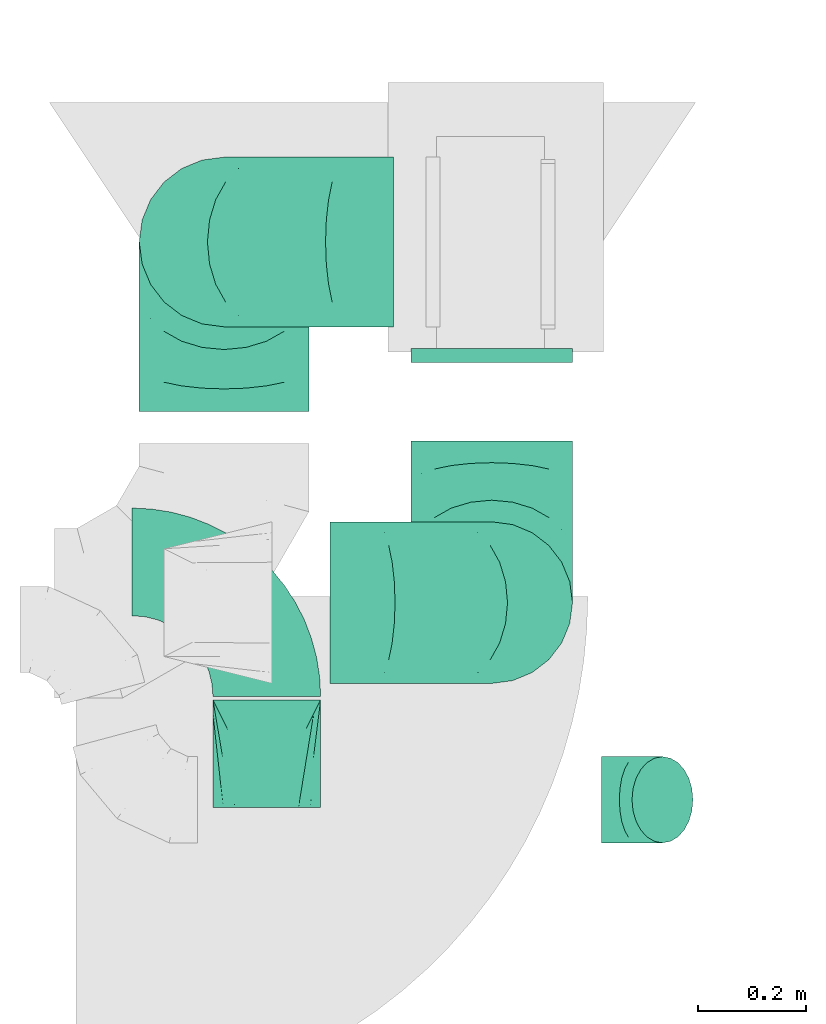
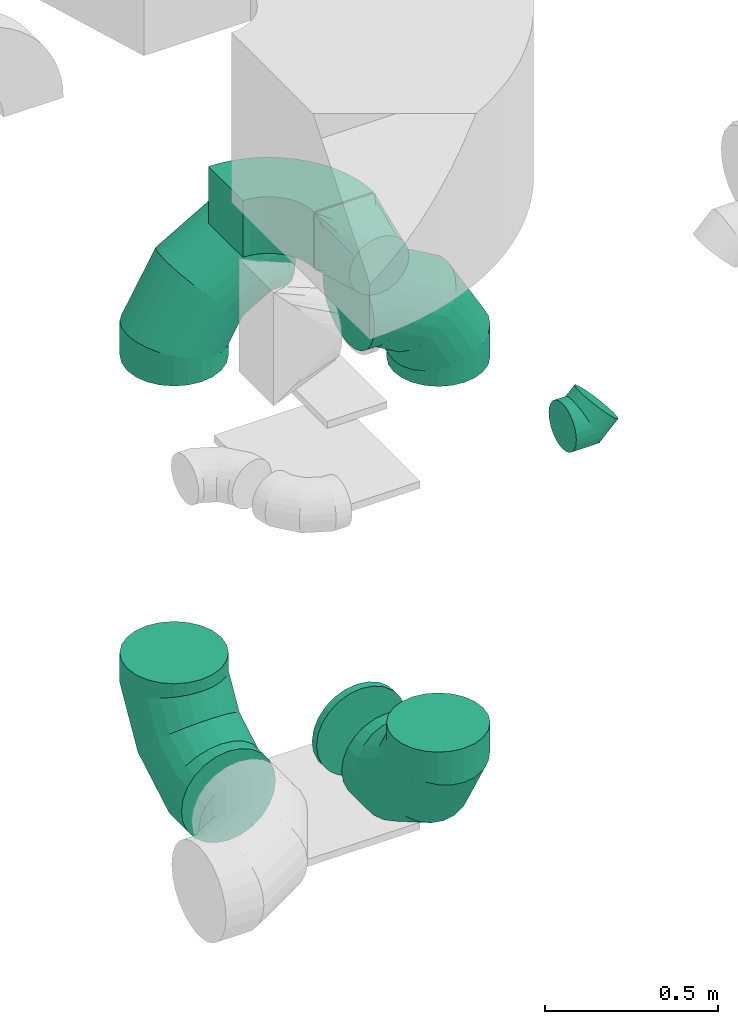
# One storey, part 32 of 59: 8 flow fittings.
"""IFC2X3 building model written with IfcOpenShell, lengths in millimetres."""

from ifc_helpers import new_model, entity, si_unit, converted_unit, derived_unit, direction, frame, frame_2d, origin, place, context, subcontext, project, spatial, polyline, circle_curve, parameter, trimmed, segment, composite_curve, outline, extrude, faceted_brep, source, transform, mapped, material, type_object, type_shapes, element, save


model = new_model("IFC2X3")

# Units and contexts
model_context = context("Model", 3, precision=0.01, world=origin(), true_north=direction((6.12303176911189e-17, 1.0)))
body_context = subcontext(model_context, "Body", "Model", "MODEL_VIEW")
ifc_project = project(units=[si_unit("LENGTHUNIT", "METRE", prefix="MILLI"), si_unit("AREAUNIT", "SQUARE_METRE"), si_unit("VOLUMEUNIT", "CUBIC_METRE"), converted_unit("PLANEANGLEUNIT", "DEGREE", entity("IfcRatioMeasure", 0.0174532925199433), si_unit("PLANEANGLEUNIT", "RADIAN"), dimensions=[0, 0, 0, 0, 0, 0, 0]), si_unit("MASSUNIT", "GRAM", prefix="KILO"), derived_unit("MASSDENSITYUNIT", [(si_unit("MASSUNIT", "GRAM", prefix="KILO"), 1), (si_unit("LENGTHUNIT", "METRE"), -3)]), derived_unit("MOMENTOFINERTIAUNIT", [(si_unit("LENGTHUNIT", "METRE"), 4)]), si_unit("TIMEUNIT", "SECOND"), si_unit("FREQUENCYUNIT", "HERTZ"), si_unit("THERMODYNAMICTEMPERATUREUNIT", "DEGREE_CELSIUS"), derived_unit("THERMALTRANSMITTANCEUNIT", [(si_unit("MASSUNIT", "GRAM", prefix="KILO"), 1), (si_unit("THERMODYNAMICTEMPERATUREUNIT", "KELVIN"), -1), (si_unit("TIMEUNIT", "SECOND"), -3)]), derived_unit("VOLUMETRICFLOWRATEUNIT", [(si_unit("LENGTHUNIT", "METRE"), 3), (si_unit("TIMEUNIT", "SECOND"), -1)]), derived_unit("MASSFLOWRATEUNIT", [(si_unit("MASSUNIT", "GRAM", prefix="KILO"), 1), (si_unit("TIMEUNIT", "SECOND"), -1)]), derived_unit("ROTATIONALFREQUENCYUNIT", [(si_unit("TIMEUNIT", "SECOND"), -1)]), si_unit("ELECTRICCURRENTUNIT", "AMPERE"), si_unit("ELECTRICVOLTAGEUNIT", "VOLT"), si_unit("POWERUNIT", "WATT"), si_unit("FORCEUNIT", "NEWTON", prefix="KILO"), si_unit("ILLUMINANCEUNIT", "LUX"), si_unit("LUMINOUSFLUXUNIT", "LUMEN"), si_unit("LUMINOUSINTENSITYUNIT", "CANDELA"), derived_unit("USERDEFINED", [(si_unit("MASSUNIT", "GRAM", prefix="KILO"), -1), (si_unit("LENGTHUNIT", "METRE"), -2), (si_unit("TIMEUNIT", "SECOND"), 3), (si_unit("LUMINOUSFLUXUNIT", "LUMEN"), 1)]), derived_unit("LINEARVELOCITYUNIT", [(si_unit("LENGTHUNIT", "METRE"), 1), (si_unit("TIMEUNIT", "SECOND"), -1)]), si_unit("PRESSUREUNIT", "PASCAL"), derived_unit("USERDEFINED", [(si_unit("LENGTHUNIT", "METRE"), -2), (si_unit("MASSUNIT", "GRAM", prefix="KILO"), 1), (si_unit("TIMEUNIT", "SECOND"), -2)]), derived_unit("LINEARFORCEUNIT", [(si_unit("MASSUNIT", "GRAM", prefix="KILO"), 1), (si_unit("LENGTHUNIT", "METRE"), 1), (si_unit("TIMEUNIT", "SECOND"), -2), (si_unit("LENGTHUNIT", "METRE"), -1)]), derived_unit("PLANARFORCEUNIT", [(si_unit("MASSUNIT", "GRAM", prefix="KILO"), 1), (si_unit("LENGTHUNIT", "METRE"), 1), (si_unit("TIMEUNIT", "SECOND"), -2), (si_unit("LENGTHUNIT", "METRE"), -2)])], contexts=[model_context])

# Site, building, storey
site_placement = place(None, origin())
site = spatial("IfcSite", under=ifc_project, at=site_placement, CompositionType="ELEMENT")
building_placement = place(site_placement, origin())
building = spatial("IfcBuilding", under=site, at=building_placement, CompositionType="ELEMENT")
storey_placement = place(building_placement, frame((0.0, 0.0, 28200.0)))
storey = spatial("IfcBuildingStorey", under=building, at=storey_placement, CompositionType="ELEMENT", Elevation=28200.0)

# Flow fittings
ifc_material = material()
duct_fitting_type_1 = type_object("IfcDuctFittingType", PredefinedType="NOTDEFINED", material=ifc_material)
shared_shape_1 = source(origin(), body_context, "Body", "Brep", [
    faceted_brep([(-66.27, 0.0, -80.0), (-66.27, -20.71, -77.27), (-66.27, -40.0, -69.28), (-66.27, -56.57, -56.57), (-66.27, -69.28, -40.0), (-66.27, -77.27, -20.71), (-66.27, -80.0, 0.0), (-66.27, -77.27, 20.71), (-66.27, -69.28, 40.0), (-66.27, -56.57, 56.57), (-66.27, -40.0, 69.28), (-66.27, -20.71, 77.27), (-66.27, 0.0, 80.0), (-66.27, 20.71, 77.27), (-66.27, 40.0, 69.28), (-66.27, 56.57, 56.57), (-66.27, 69.28, 40.0), (-66.27, 77.27, 20.71), (-66.27, 80.0, 0.0), (-66.27, 77.27, -20.71), (-66.27, 69.28, -40.0), (-66.27, 56.57, -56.57), (-66.27, 40.0, -69.28), (-66.27, 20.71, -77.27), (-8.58, 20.71, 77.27), (-16.57, 40.0, 69.28), (0.0, 0.0, 80.0), (-23.43, 56.57, 56.57), (-28.7, 69.28, 40.0), (-32.01, 77.27, 20.71), (-33.14, 80.0, 0.0), (-32.01, 77.27, -20.71), (-28.7, 69.28, -40.0), (-23.43, 56.57, -56.57), (-8.58, 20.71, -77.27), (0.0, 0.0, -80.0), (-16.57, 40.0, -69.28), (8.58, -20.71, -77.27), (16.57, -40.0, -69.28), (23.43, -56.57, -56.57), (28.7, -69.28, -40.0), (32.01, -77.27, -20.71), (33.14, -80.0, 0.0), (32.01, -77.27, 20.71), (28.7, -69.28, 40.0), (23.43, -56.57, 56.57), (16.57, -40.0, 69.28), (8.58, -20.71, 77.27), (46.86, 46.86, 80.0), (32.22, 61.5, 77.27), (18.58, 75.15, 69.28), (6.86, 86.86, 56.57), (-2.13, 95.85, 40.0), (-7.78, 101.5, 20.71), (-9.71, 103.43, 0.0), (-7.78, 101.5, -20.71), (-2.13, 95.85, -40.0), (6.86, 86.86, -56.57), (18.58, 75.15, -69.28), (32.22, 61.5, -77.27), (46.86, 46.86, -80.0), (61.5, 32.22, -77.27), (75.15, 18.58, -69.28), (86.86, 6.86, -56.57), (95.85, -2.13, -40.0), (101.5, -7.78, -20.71), (103.43, -9.71, 0.0), (101.5, -7.78, 20.71), (95.85, -2.13, 40.0), (86.86, 6.86, 56.57), (75.15, 18.58, 69.28), (61.5, 32.22, 77.27)], [[[0, 1, 2, 3, 4, 5, 6, 7, 8, 9, 10, 11, 12, 13, 14, 15, 16, 17, 18, 19, 20, 21, 22, 23]], [[24, 25, 14, 13]], [[26, 24, 13, 12]], [[14, 25, 27, 15]], [[28, 29, 17, 16]], [[28, 16, 15, 27]], [[30, 18, 17, 29]], [[31, 32, 20, 19]], [[30, 31, 19, 18]], [[32, 33, 21, 20]], [[34, 35, 0, 23]], [[36, 34, 23, 22]], [[33, 36, 22, 21]], [[1, 0, 35, 37]], [[2, 1, 37, 38]], [[38, 39, 3, 2]], [[5, 4, 40, 41]], [[6, 5, 41, 42]], [[39, 40, 4, 3]], [[6, 42, 43, 7]], [[7, 43, 44, 8]], [[8, 44, 45, 9]], [[9, 45, 46, 10]], [[10, 46, 47, 11]], [[26, 12, 11, 47]], [[24, 26, 48, 49]], [[25, 24, 49, 50]], [[27, 25, 50, 51]], [[29, 28, 52, 53]], [[30, 29, 53, 54]], [[51, 52, 28, 27]], [[30, 54, 55, 31]], [[31, 55, 56, 32]], [[57, 33, 32, 56]], [[36, 58, 59, 34]], [[34, 59, 60, 35]], [[58, 36, 33, 57]], [[35, 60, 61, 37]], [[37, 61, 62, 38]], [[63, 39, 38, 62]], [[40, 64, 65, 41]], [[41, 65, 66, 42]], [[64, 40, 39, 63]], [[43, 42, 66, 67]], [[44, 43, 67, 68]], [[68, 69, 45, 44]], [[47, 46, 70, 71]], [[26, 47, 71, 48]], [[69, 70, 46, 45]], [[59, 58, 57, 56, 55, 54, 53, 52, 51, 50, 49, 48, 71, 70, 69, 68, 67, 66, 65, 64, 63, 62, 61, 60]]]),
])
type_shapes(duct_fitting_type_1, [shared_shape_1])
flow_fitting_1_placement = place(storey_placement, frame((54162.65, 11858.0, 2105.0), z_axis=(0.0, 1.0, 0.0), x_axis=(-0.707106781186544, 0.0, -0.707106781186551)))
element("IfcFlowFitting", 1, at=flow_fitting_1_placement, inside=storey, type_object=duct_fitting_type_1, material=ifc_material, context=body_context, shape_type="MappedRepresentation", body=[
    mapped(shared_shape_1, transform((0.0, 0.0, 0.0), scale=1.0)),
])
duct_fitting_type_2 = type_object("IfcDuctFittingType", PredefinedType="NOTDEFINED", material=ifc_material)
shared_shape_2 = source(origin(), body_context, "Body", "Brep", [
    faceted_brep([(-315.0, 0.0, -157.5), (-315.0, -40.76, -152.13), (-315.0, -78.75, -136.4), (-315.0, -111.37, -111.37), (-315.0, -136.4, -78.75), (-315.0, -152.13, -40.76), (-315.0, -157.5, 0.0), (-315.0, -152.13, 40.76), (-315.0, -136.4, 78.75), (-315.0, -111.37, 111.37), (-315.0, -78.75, 136.4), (-315.0, -40.76, 152.13), (-315.0, 0.0, 157.5), (-315.0, 40.76, 152.13), (-315.0, 78.75, 136.4), (-315.0, 111.37, 111.37), (-315.0, 136.4, 78.75), (-315.0, 152.13, 40.76), (-315.0, 157.5, 0.0), (-315.0, 152.13, -40.76), (-315.0, 136.4, -78.75), (-315.0, 111.37, -111.37), (-315.0, 78.75, -136.4), (-315.0, 40.76, -152.13), (-241.52, 40.76, 152.13), (-251.7, 78.75, 136.4), (-230.6, 0.0, 157.5), (-260.44, 111.37, 111.37), (-271.36, 152.13, 40.76), (-272.8, 157.5, 0.0), (-267.14, 136.4, 78.75), (-267.14, 136.4, -78.75), (-260.44, 111.37, -111.37), (-271.36, 152.13, -40.76), (-241.52, 40.76, -152.13), (-230.6, 0.0, -157.5), (-251.7, 78.75, -136.4), (-219.67, -40.76, -152.13), (-209.5, -78.75, -136.4), (-200.75, -111.37, -111.37), (-194.05, -136.4, -78.75), (-189.83, -152.13, -40.76), (-188.39, -157.5, 0.0), (-189.83, -152.13, 40.76), (-194.05, -136.4, 78.75), (-200.75, -111.37, 111.37), (-209.5, -78.75, 136.4), (-219.67, -40.76, 152.13), (-114.25, 114.25, 152.13), (-142.05, 142.05, 136.4), (-84.4, 84.4, 157.5), (-165.93, 165.93, 111.37), (-184.25, 184.25, 78.75), (-195.77, 195.77, 40.76), (-199.7, 199.7, 0.0), (-195.77, 195.77, -40.76), (-184.25, 184.25, -78.75), (-165.93, 165.93, -111.37), (-114.25, 114.25, -152.13), (-84.4, 84.4, -157.5), (-142.05, 142.05, -136.4), (-54.56, 54.56, -152.13), (-26.75, 26.75, -136.4), (-2.88, 2.88, -111.37), (15.45, -15.45, -78.75), (26.97, -26.97, -40.76), (30.89, -30.89, 0.0), (26.97, -26.97, 40.76), (15.45, -15.45, 78.75), (-2.88, 2.88, 111.37), (-26.75, 26.75, 136.4), (-54.56, 54.56, 152.13), (-40.76, 241.52, 152.13), (-78.75, 251.7, 136.4), (0.0, 230.6, 157.5), (-111.37, 260.44, 111.37), (-136.4, 267.14, 78.75), (-152.13, 271.36, 40.76), (-157.5, 272.8, 0.0), (-152.13, 271.36, -40.76), (-136.4, 267.14, -78.75), (-111.37, 260.44, -111.37), (-40.76, 241.52, -152.13), (0.0, 230.6, -157.5), (-78.75, 251.7, -136.4), (40.76, 219.67, -152.13), (78.75, 209.5, -136.4), (111.37, 200.75, -111.37), (136.4, 194.05, -78.75), (152.13, 189.83, -40.76), (157.5, 188.39, 0.0), (152.13, 189.83, 40.76), (136.4, 194.05, 78.75), (111.37, 200.75, 111.37), (78.75, 209.5, 136.4), (40.76, 219.67, 152.13), (-40.76, 315.0, -152.13), (-78.75, 315.0, -136.4), (-111.37, 315.0, -111.37), (-136.4, 315.0, -78.75), (-152.13, 315.0, -40.76), (-157.5, 315.0, 0.0), (-152.13, 315.0, 40.76), (-136.4, 315.0, 78.75), (-111.37, 315.0, 111.37), (-78.75, 315.0, 136.4), (-40.76, 315.0, 152.13), (0.0, 315.0, 157.5), (40.76, 315.0, 152.13), (78.75, 315.0, 136.4), (111.37, 315.0, 111.37), (136.4, 315.0, 78.75), (152.13, 315.0, 40.76), (157.5, 315.0, 0.0), (152.13, 315.0, -40.76), (136.4, 315.0, -78.75), (111.37, 315.0, -111.37), (78.75, 315.0, -136.4), (40.76, 315.0, -152.13), (0.0, 315.0, -157.5)], [[[0, 1, 2, 3, 4, 5, 6, 7, 8, 9, 10, 11, 12, 13, 14, 15, 16, 17, 18, 19, 20, 21, 22, 23]], [[24, 25, 14, 13]], [[26, 24, 13, 12]], [[14, 25, 27, 15]], [[28, 29, 18, 17]], [[30, 28, 17, 16]], [[15, 27, 30, 16]], [[20, 31, 32, 21]], [[33, 31, 20, 19]], [[18, 29, 33, 19]], [[34, 35, 0, 23]], [[36, 34, 23, 22]], [[32, 36, 22, 21]], [[1, 0, 35, 37]], [[2, 1, 37, 38]], [[38, 39, 3, 2]], [[5, 4, 40, 41]], [[6, 5, 41, 42]], [[39, 40, 4, 3]], [[6, 42, 43, 7]], [[7, 43, 44, 8]], [[8, 44, 45, 9]], [[9, 45, 46, 10]], [[10, 46, 47, 11]], [[26, 12, 11, 47]], [[48, 49, 25, 24]], [[50, 48, 24, 26]], [[27, 25, 49, 51]], [[52, 53, 28, 30]], [[51, 52, 30, 27]], [[29, 28, 53, 54]], [[55, 56, 31, 33]], [[54, 55, 33, 29]], [[32, 31, 56, 57]], [[58, 59, 35, 34]], [[60, 58, 34, 36]], [[57, 60, 36, 32]], [[37, 35, 59, 61]], [[38, 37, 61, 62]], [[39, 38, 62, 63]], [[41, 40, 64, 65]], [[42, 41, 65, 66]], [[63, 64, 40, 39]], [[43, 42, 66, 67]], [[44, 43, 67, 68]], [[68, 69, 45, 44]], [[46, 45, 69, 70]], [[47, 46, 70, 71]], [[26, 47, 71, 50]], [[72, 73, 49, 48]], [[74, 72, 48, 50]], [[51, 49, 73, 75]], [[76, 77, 53, 52]], [[75, 76, 52, 51]], [[54, 53, 77, 78]], [[79, 80, 56, 55]], [[78, 79, 55, 54]], [[57, 56, 80, 81]], [[82, 83, 59, 58]], [[84, 82, 58, 60]], [[81, 84, 60, 57]], [[61, 59, 83, 85]], [[62, 61, 85, 86]], [[63, 62, 86, 87]], [[65, 64, 88, 89]], [[66, 65, 89, 90]], [[87, 88, 64, 63]], [[67, 66, 90, 91]], [[68, 67, 91, 92]], [[92, 93, 69, 68]], [[70, 69, 93, 94]], [[71, 70, 94, 95]], [[50, 71, 95, 74]], [[96, 97, 98, 99, 100, 101, 102, 103, 104, 105, 106, 107, 108, 109, 110, 111, 112, 113, 114, 115, 116, 117, 118, 119]], [[106, 105, 73, 72]], [[107, 106, 72, 74]], [[75, 73, 105, 104]], [[77, 76, 103, 102]], [[78, 77, 102, 101]], [[104, 103, 76, 75]], [[78, 101, 100, 79]], [[79, 100, 99, 80]], [[98, 81, 80, 99]], [[84, 97, 96, 82]], [[82, 96, 119, 83]], [[97, 84, 81, 98]], [[83, 119, 118, 85]], [[85, 118, 117, 86]], [[116, 87, 86, 117]], [[88, 115, 114, 89]], [[89, 114, 113, 90]], [[115, 88, 87, 116]], [[91, 90, 113, 112]], [[92, 91, 112, 111]], [[111, 110, 93, 92]], [[95, 94, 109, 108]], [[74, 95, 108, 107]], [[110, 109, 94, 93]]]),
])
type_shapes(duct_fitting_type_2, [shared_shape_2])
for number, where, z_axis, x_axis in (
    (2, (53395.67, 12893.51, 607.5), (1.0, 0.0, 0.0), (0.0, 1.0, 0.0)),
    (3, (53395.67, 12893.51, 2289.55), (0.0, 1.0, 0.0), (0.0, 0.0, 1.0)),
):
    element("IfcFlowFitting", number, at=place(storey_placement, frame(where, z_axis=z_axis, x_axis=x_axis)), inside=storey, type_object=duct_fitting_type_2, material=ifc_material, context=body_context, shape_type="MappedRepresentation", body=[
        mapped(shared_shape_2, transform((0.0, 0.0, 0.0), scale=1.0)),
    ])
duct_fitting_type_3 = type_object("IfcDuctFittingType", PredefinedType="NOTDEFINED", material=ifc_material)
shared_shape_3 = source(origin(), body_context, "Body", "Brep", [
    faceted_brep([(200.0, 30.9, 95.11), (200.0, 19.08, 96.98), (200.0, 9.54, 98.49), (200.0, 4.77, 99.24), (200.0, 0.0, 100.0), (200.0, -4.77, 99.24), (200.0, -9.54, 98.49), (200.0, -19.08, 96.98), (200.0, -30.9, 95.11), (200.0, -44.84, 88.0), (200.0, -58.78, 80.9), (200.0, -69.84, 69.84), (200.0, -80.9, 58.78), (200.0, -88.0, 44.84), (200.0, -95.11, 30.9), (200.0, -96.98, 19.08), (200.0, -98.49, 9.54), (200.0, -99.24, 4.77), (200.0, -100.0, 0.0), (200.0, -99.24, -4.77), (200.0, -98.49, -9.54), (200.0, -96.98, -19.08), (200.0, -95.11, -30.9), (200.0, -88.0, -44.84), (200.0, -80.9, -58.78), (200.0, -69.84, -69.84), (200.0, -58.78, -80.9), (200.0, -44.84, -88.0), (200.0, -30.9, -95.11), (200.0, -19.08, -96.98), (200.0, -9.54, -98.49), (200.0, -4.77, -99.24), (200.0, 0.0, -100.0), (200.0, 4.77, -99.24), (200.0, 9.54, -98.49), (200.0, 19.08, -96.98), (200.0, 30.9, -95.11), (200.0, 44.84, -88.0), (200.0, 58.78, -80.9), (200.0, 69.84, -69.84), (200.0, 80.9, -58.78), (200.0, 88.0, -44.84), (200.0, 95.11, -30.9), (200.0, 96.98, -19.08), (200.0, 98.49, -9.54), (200.0, 99.24, -4.77), (200.0, 100.0, 0.0), (200.0, 99.24, 4.77), (200.0, 98.49, 9.54), (200.0, 96.98, 19.08), (200.0, 95.11, 30.9), (200.0, 88.0, 44.84), (200.0, 80.9, 58.78), (200.0, 69.84, 69.84), (200.0, 58.78, 80.9), (200.0, 44.84, 88.0), (0.0, -100.0, 100.0), (0.0, 100.0, 100.0), (0.0, 100.0, -100.0), (0.0, -100.0, -100.0), (104.11, -47.94, 100.0), (100.0, -83.15, 87.43), (26.03, -86.99, 100.0), (78.09, -60.96, 100.0), (52.06, -73.97, 100.0), (188.01, -5.99, 100.0), (176.03, -11.99, 100.0), (152.06, -23.97, 100.0), (128.09, -35.96, 100.0), (52.06, -100.0, 73.97), (78.09, -100.0, 60.96), (104.11, -100.0, 47.94), (128.09, -100.0, 35.96), (152.06, -100.0, 23.97), (176.03, -100.0, 11.99), (188.01, -100.0, 5.99), (26.03, -100.0, 86.99), (26.03, -100.0, -86.99), (52.06, -100.0, -73.97), (78.09, -100.0, -60.96), (104.11, -100.0, -47.94), (128.09, -100.0, -35.96), (152.06, -100.0, -23.97), (176.03, -100.0, -11.99), (188.01, -100.0, -5.99), (100.0, -87.43, -83.15), (52.06, -73.97, -100.0), (78.09, -60.96, -100.0), (104.11, -47.94, -100.0), (128.09, -35.96, -100.0), (152.06, -23.97, -100.0), (176.03, -11.99, -100.0), (188.01, -5.99, -100.0), (26.03, -86.99, -100.0), (26.03, 86.99, -100.0), (52.06, 73.97, -100.0), (78.09, 60.96, -100.0), (104.11, 47.94, -100.0), (128.09, 35.96, -100.0), (152.06, 23.97, -100.0), (176.03, 11.99, -100.0), (188.01, 5.99, -100.0), (100.0, 83.15, -87.43), (52.06, 100.0, -73.97), (78.09, 100.0, -60.96), (104.11, 100.0, -47.94), (128.09, 100.0, -35.96), (152.06, 100.0, -23.97), (176.03, 100.0, -11.99), (188.01, 100.0, -5.99), (26.03, 100.0, -86.99), (26.03, 100.0, 86.99), (52.06, 100.0, 73.97), (78.09, 100.0, 60.96), (104.11, 100.0, 47.94), (128.09, 100.0, 35.96), (152.06, 100.0, 23.97), (176.03, 100.0, 11.99), (188.01, 100.0, 5.99), (100.0, 87.43, 83.15), (52.06, 73.97, 100.0), (78.09, 60.96, 100.0), (104.11, 47.94, 100.0), (128.09, 35.96, 100.0), (152.06, 23.97, 100.0), (176.03, 11.99, 100.0), (188.01, 5.99, 100.0), (26.03, 86.99, 100.0)], [[[0, 1, 2, 3, 4, 5, 6, 7, 8, 9, 10, 11, 12, 13, 14, 15, 16, 17, 18, 19, 20, 21, 22, 23, 24, 25, 26, 27, 28, 29, 30, 31, 32, 33, 34, 35, 36, 37, 38, 39, 40, 41, 42, 43, 44, 45, 46, 47, 48, 49, 50, 51, 52, 53, 54, 55]], [[56, 57, 58, 59]], [[60, 9, 8]], [[56, 61, 62]], [[9, 60, 63, 64]], [[65, 66, 67, 68, 60, 8, 7, 6, 5, 4]], [[62, 61, 10]], [[13, 69, 70, 71]], [[64, 10, 9]], [[14, 71, 72, 73, 74, 75, 18, 17, 16, 15]], [[12, 76, 69]], [[71, 14, 13]], [[61, 76, 11]], [[10, 64, 62]], [[76, 12, 11]], [[10, 61, 11]], [[61, 56, 76]], [[69, 13, 12]], [[75, 74, 73, 72, 71, 70, 69, 76, 56, 59, 77, 78, 79, 80, 81, 82, 83, 84, 18]], [[80, 23, 22]], [[59, 85, 77]], [[23, 80, 79, 78]], [[84, 83, 82, 81, 80, 22, 21, 20, 19, 18]], [[77, 85, 24]], [[27, 86, 87, 88]], [[78, 24, 23]], [[28, 88, 89, 90, 91, 92, 32, 31, 30, 29]], [[26, 93, 86]], [[88, 28, 27]], [[85, 93, 25]], [[24, 78, 77]], [[93, 26, 25]], [[24, 85, 25]], [[85, 59, 93]], [[86, 27, 26]], [[92, 91, 90, 89, 88, 87, 86, 93, 59, 58, 94, 95, 96, 97, 98, 99, 100, 101, 32]], [[97, 37, 36]], [[58, 102, 94]], [[37, 97, 96, 95]], [[101, 100, 99, 98, 97, 36, 35, 34, 33, 32]], [[94, 102, 38]], [[41, 103, 104, 105]], [[95, 38, 37]], [[42, 105, 106, 107, 108, 109, 46, 45, 44, 43]], [[40, 110, 103]], [[105, 42, 41]], [[102, 110, 39]], [[38, 95, 94]], [[110, 40, 39]], [[38, 102, 39]], [[102, 58, 110]], [[103, 41, 40]], [[58, 57, 111, 112, 113, 114, 115, 116, 117, 118, 46, 109, 108, 107, 106, 105, 104, 103, 110]], [[114, 51, 50]], [[57, 119, 111]], [[51, 114, 113, 112]], [[118, 117, 116, 115, 114, 50, 49, 48, 47, 46]], [[111, 119, 52]], [[55, 120, 121, 122]], [[112, 52, 51]], [[0, 122, 123, 124, 125, 126, 4, 3, 2, 1]], [[54, 127, 120]], [[122, 0, 55]], [[119, 127, 53]], [[52, 112, 111]], [[127, 54, 53]], [[52, 119, 53]], [[119, 57, 127]], [[120, 55, 54]], [[57, 56, 62, 64, 63, 60, 68, 67, 66, 65, 4, 126, 125, 124, 123, 122, 121, 120, 127]]]),
])
type_shapes(duct_fitting_type_3, [shared_shape_3])
flow_fitting_2_placement = place(storey_placement, frame((53475.03, 12043.59, 2900.0), z_axis=(0.0, -7.58971469204016e-07, 1.0), x_axis=(0.0, -1.0, -7.58971469204016e-07)))
element("IfcFlowFitting", 4, at=flow_fitting_2_placement, inside=storey, type_object=duct_fitting_type_3, material=ifc_material, context=body_context, shape_type="MappedRepresentation", body=[
    mapped(shared_shape_3, transform((0.0, 0.0, 0.0), scale=1.0)),
])
duct_fitting_type_4 = type_object("IfcDuctFittingType", PredefinedType="NOTDEFINED", material=ifc_material)
shared_shape_4 = source(origin(), body_context, "Body", "Brep", [
    faceted_brep([(-300.0, 0.0, -150.0), (-300.0, -38.82, -144.89), (-300.0, -75.0, -129.9), (-300.0, -106.07, -106.07), (-300.0, -129.9, -75.0), (-300.0, -144.89, -38.82), (-300.0, -150.0, 0.0), (-300.0, -144.89, 38.82), (-300.0, -129.9, 75.0), (-300.0, -106.07, 106.07), (-300.0, -75.0, 129.9), (-300.0, -38.82, 144.89), (-300.0, 0.0, 150.0), (-300.0, 38.82, 144.89), (-300.0, 75.0, 129.9), (-300.0, 106.07, 106.07), (-300.0, 129.9, 75.0), (-300.0, 144.89, 38.82), (-300.0, 150.0, 0.0), (-300.0, 144.89, -38.82), (-300.0, 129.9, -75.0), (-300.0, 106.07, -106.07), (-300.0, 75.0, -129.9), (-300.0, 38.82, -144.89), (-230.02, 38.82, 144.89), (-239.71, 75.0, 129.9), (-219.62, 0.0, 150.0), (-248.04, 106.07, 106.07), (-258.44, 144.89, 38.82), (-259.81, 150.0, 0.0), (-254.42, 129.9, 75.0), (-254.42, 129.9, -75.0), (-248.04, 106.07, -106.07), (-258.44, 144.89, -38.82), (-230.02, 38.82, -144.89), (-219.62, 0.0, -150.0), (-239.71, 75.0, -129.9), (-209.21, -38.82, -144.89), (-199.52, -75.0, -129.9), (-191.19, -106.07, -106.07), (-184.81, -129.9, -75.0), (-180.79, -144.89, -38.82), (-179.42, -150.0, 0.0), (-180.79, -144.89, 38.82), (-184.81, -129.9, 75.0), (-191.19, -106.07, 106.07), (-199.52, -75.0, 129.9), (-209.21, -38.82, 144.89), (-108.81, 108.81, 144.89), (-135.29, 135.29, 129.9), (-80.38, 80.38, 150.0), (-158.03, 158.03, 106.07), (-175.48, 175.48, 75.0), (-186.45, 186.45, 38.82), (-190.19, 190.19, 0.0), (-186.45, 186.45, -38.82), (-175.48, 175.48, -75.0), (-158.03, 158.03, -106.07), (-108.81, 108.81, -144.89), (-80.38, 80.38, -150.0), (-135.29, 135.29, -129.9), (-51.96, 51.96, -144.89), (-25.48, 25.48, -129.9), (-2.74, 2.74, -106.07), (14.71, -14.71, -75.0), (25.68, -25.68, -38.82), (29.42, -29.42, 0.0), (25.68, -25.68, 38.82), (14.71, -14.71, 75.0), (-2.74, 2.74, 106.07), (-25.48, 25.48, 129.9), (-51.96, 51.96, 144.89), (-38.82, 230.02, 144.89), (-75.0, 239.71, 129.9), (0.0, 219.62, 150.0), (-106.07, 248.04, 106.07), (-129.9, 254.42, 75.0), (-144.89, 258.44, 38.82), (-150.0, 259.81, 0.0), (-144.89, 258.44, -38.82), (-129.9, 254.42, -75.0), (-106.07, 248.04, -106.07), (-38.82, 230.02, -144.89), (0.0, 219.62, -150.0), (-75.0, 239.71, -129.9), (38.82, 209.21, -144.89), (75.0, 199.52, -129.9), (106.07, 191.19, -106.07), (129.9, 184.81, -75.0), (144.89, 180.79, -38.82), (150.0, 179.42, 0.0), (144.89, 180.79, 38.82), (129.9, 184.81, 75.0), (106.07, 191.19, 106.07), (75.0, 199.52, 129.9), (38.82, 209.21, 144.89), (-150.0, 300.0, 0.0), (-144.89, 300.0, 38.82), (-129.9, 300.0, 75.0), (-106.07, 300.0, 106.07), (-75.0, 300.0, 129.9), (-38.82, 300.0, 144.89), (0.0, 300.0, 150.0), (38.82, 300.0, 144.89), (75.0, 300.0, 129.9), (106.07, 300.0, 106.07), (129.9, 300.0, 75.0), (144.89, 300.0, 38.82), (150.0, 300.0, 0.0), (144.89, 300.0, -38.82), (129.9, 300.0, -75.0), (106.07, 300.0, -106.07), (75.0, 300.0, -129.9), (38.82, 300.0, -144.89), (0.0, 300.0, -150.0), (-38.82, 300.0, -144.89), (-75.0, 300.0, -129.9), (-106.07, 300.0, -106.07), (-129.9, 300.0, -75.0), (-144.89, 300.0, -38.82)], [[[0, 1, 2, 3, 4, 5, 6, 7, 8, 9, 10, 11, 12, 13, 14, 15, 16, 17, 18, 19, 20, 21, 22, 23]], [[24, 25, 14, 13]], [[26, 24, 13, 12]], [[14, 25, 27, 15]], [[28, 29, 18, 17]], [[30, 28, 17, 16]], [[15, 27, 30, 16]], [[20, 31, 32, 21]], [[33, 31, 20, 19]], [[18, 29, 33, 19]], [[34, 35, 0, 23]], [[36, 34, 23, 22]], [[32, 36, 22, 21]], [[1, 0, 35, 37]], [[2, 1, 37, 38]], [[38, 39, 3, 2]], [[5, 4, 40, 41]], [[6, 5, 41, 42]], [[39, 40, 4, 3]], [[6, 42, 43, 7]], [[7, 43, 44, 8]], [[8, 44, 45, 9]], [[9, 45, 46, 10]], [[10, 46, 47, 11]], [[26, 12, 11, 47]], [[48, 49, 25, 24]], [[50, 48, 24, 26]], [[27, 25, 49, 51]], [[52, 53, 28, 30]], [[51, 52, 30, 27]], [[29, 28, 53, 54]], [[55, 56, 31, 33]], [[54, 55, 33, 29]], [[32, 31, 56, 57]], [[58, 59, 35, 34]], [[60, 58, 34, 36]], [[57, 60, 36, 32]], [[37, 35, 59, 61]], [[38, 37, 61, 62]], [[39, 38, 62, 63]], [[41, 40, 64, 65]], [[42, 41, 65, 66]], [[63, 64, 40, 39]], [[43, 42, 66, 67]], [[44, 43, 67, 68]], [[68, 69, 45, 44]], [[46, 45, 69, 70]], [[47, 46, 70, 71]], [[26, 47, 71, 50]], [[72, 73, 49, 48]], [[74, 72, 48, 50]], [[51, 49, 73, 75]], [[76, 77, 53, 52]], [[75, 76, 52, 51]], [[54, 53, 77, 78]], [[79, 80, 56, 55]], [[78, 79, 55, 54]], [[57, 56, 80, 81]], [[82, 83, 59, 58]], [[84, 82, 58, 60]], [[81, 84, 60, 57]], [[61, 59, 83, 85]], [[62, 61, 85, 86]], [[63, 62, 86, 87]], [[65, 64, 88, 89]], [[66, 65, 89, 90]], [[87, 88, 64, 63]], [[67, 66, 90, 91]], [[68, 67, 91, 92]], [[92, 93, 69, 68]], [[70, 69, 93, 94]], [[71, 70, 94, 95]], [[50, 71, 95, 74]], [[96, 97, 98, 99, 100, 101, 102, 103, 104, 105, 106, 107, 108, 109, 110, 111, 112, 113, 114, 115, 116, 117, 118, 119]], [[101, 100, 73, 72]], [[102, 101, 72, 74]], [[75, 73, 100, 99]], [[77, 76, 98, 97]], [[78, 77, 97, 96]], [[99, 98, 76, 75]], [[119, 118, 80, 79]], [[96, 119, 79, 78]], [[117, 81, 80, 118]], [[84, 116, 115, 82]], [[82, 115, 114, 83]], [[116, 84, 81, 117]], [[83, 114, 113, 85]], [[85, 113, 112, 86]], [[111, 87, 86, 112]], [[88, 110, 109, 89]], [[89, 109, 108, 90]], [[110, 88, 87, 111]], [[91, 90, 108, 107]], [[92, 91, 107, 106]], [[106, 105, 93, 92]], [[95, 94, 104, 103]], [[74, 95, 103, 102]], [[105, 104, 94, 93]]]),
])
type_shapes(duct_fitting_type_4, [shared_shape_4])
for number, where, z_axis, x_axis in (
    (5, (53892.53, 12224.0, 2500.0), (0.0, -1.0, 0.0), (0.0, 0.0, 1.0)),
    (6, (53892.53, 12224.0, 607.5), (1.0, 0.0, 0.0), (0.0, 0.0, -1.0)),
):
    element("IfcFlowFitting", number, at=place(storey_placement, frame(where, z_axis=z_axis, x_axis=x_axis)), inside=storey, type_object=duct_fitting_type_4, material=ifc_material, context=body_context, shape_type="MappedRepresentation", body=[
        mapped(shared_shape_4, transform((0.0, 0.0, 0.0), scale=1.0)),
    ])
duct_fitting_type_5 = type_object("IfcDuctFittingType", PredefinedType="NOTDEFINED", material=ifc_material)
shared_shape_5 = source(origin(), body_context, "Body", "Brep", [
    faceted_brep([(20.0, 0.0, -150.0), (20.0, 38.82, -144.89), (20.0, 75.0, -129.9), (20.0, 106.07, -106.07), (20.0, 129.9, -75.0), (20.0, 144.89, -38.82), (20.0, 150.0, 0.0), (20.0, 144.89, 38.82), (20.0, 129.9, 75.0), (20.0, 106.07, 106.07), (20.0, 75.0, 129.9), (20.0, 38.82, 144.89), (20.0, 0.0, 150.0), (20.0, -38.82, 144.89), (20.0, -75.0, 129.9), (20.0, -106.07, 106.07), (20.0, -129.9, 75.0), (20.0, -144.89, 38.82), (20.0, -150.0, 0.0), (20.0, -144.89, -38.82), (20.0, -129.9, -75.0), (20.0, -106.07, -106.07), (20.0, -75.0, -129.9), (20.0, -38.82, -144.89), (0.0, 0.0, 150.0), (-6.1, 0.0, 150.0), (-6.1, -38.82, 144.89), (0.0, -38.82, 144.89), (-6.1, -75.0, 129.9), (0.0, -75.0, 129.9), (0.0, -106.07, 106.07), (-6.1, -106.07, 106.07), (0.0, -129.9, 75.0), (-6.1, -129.9, 75.0), (-6.1, -144.89, 38.82), (0.0, -144.89, 38.82), (-6.1, -150.0, 0.0), (0.0, -150.0, 0.0), (-6.1, -144.89, -38.82), (0.0, -144.89, -38.82), (-6.1, -129.9, -75.0), (0.0, -129.9, -75.0), (0.0, -106.07, -106.07), (-6.1, -106.07, -106.07), (0.0, -75.0, -129.9), (-6.1, -75.0, -129.9), (-6.1, -38.82, -144.89), (0.0, -38.82, -144.89), (-6.1, 0.0, -150.0), (0.0, 0.0, -150.0), (-6.1, 38.82, -144.89), (0.0, 38.82, -144.89), (-6.1, 75.0, -129.9), (0.0, 75.0, -129.9), (0.0, 106.07, -106.07), (-6.1, 106.07, -106.07), (0.0, 129.9, -75.0), (-6.1, 129.9, -75.0), (-6.1, 144.89, -38.82), (0.0, 144.89, -38.82), (-6.1, 150.0, 0.0), (0.0, 150.0, 0.0), (-6.1, 144.89, 38.82), (0.0, 144.89, 38.82), (-6.1, 129.9, 75.0), (0.0, 129.9, 75.0), (0.0, 106.07, 106.07), (-6.1, 106.07, 106.07), (0.0, 75.0, 129.9), (-6.1, 75.0, 129.9), (-6.1, 38.82, 144.89), (0.0, 38.82, 144.89)], [[[0, 1, 2, 3, 4, 5, 6, 7, 8, 9, 10, 11, 12, 13, 14, 15, 16, 17, 18, 19, 20, 21, 22, 23]], [[13, 12, 24, 25, 26, 27]], [[14, 13, 27, 26, 28, 29]], [[30, 15, 14, 29, 28, 31]], [[17, 16, 32, 33, 34, 35]], [[18, 17, 35, 34, 36, 37]], [[32, 16, 15, 30, 31, 33]], [[19, 18, 37, 36, 38, 39]], [[20, 19, 39, 38, 40, 41]], [[42, 21, 20, 41, 40, 43]], [[23, 22, 44, 45, 46, 47]], [[0, 23, 47, 46, 48, 49]], [[44, 22, 21, 42, 43, 45]], [[1, 0, 49, 48, 50, 51]], [[2, 1, 51, 50, 52, 53]], [[54, 3, 2, 53, 52, 55]], [[5, 4, 56, 57, 58, 59]], [[6, 5, 59, 58, 60, 61]], [[56, 4, 3, 54, 55, 57]], [[7, 6, 61, 60, 62, 63]], [[8, 7, 63, 62, 64, 65]], [[66, 9, 8, 65, 64, 67]], [[11, 10, 68, 69, 70, 71]], [[12, 11, 71, 70, 25, 24]], [[68, 10, 9, 66, 67, 69]], [[46, 45, 43, 40, 38, 36, 34, 33, 31, 28, 26, 25, 70, 69, 67, 64, 62, 60, 58, 57, 55, 52, 50, 48]]]),
])
type_shapes(duct_fitting_type_5, [shared_shape_5])
flow_fitting_3_placement = place(storey_placement, frame((53892.53, 12689.46, 607.5), z_axis=(-1.0, 0.0, 0.0), x_axis=(0.0, -1.0, 0.0)))
element("IfcFlowFitting", 7, at=flow_fitting_3_placement, inside=storey, type_object=duct_fitting_type_5, material=ifc_material, context=body_context, shape_type="MappedRepresentation", body=[
    mapped(shared_shape_5, transform((0.0, 0.0, 0.0), scale=1.0)),
])
duct_fitting_type_6 = type_object("IfcDuctFittingType", PredefinedType="NOTDEFINED", material=ifc_material)
shared_shape_6 = source(origin(), body_context, "Body", "SweptSolid", [
    extrude(outline(composite_curve([segment(polyline([(-225.0, -125.0), (-25.0, -125.0)]), True, "CONTINUOUS"), segment(trimmed(circle_curve(frame_2d((125.0, -125.0), x_axis=(0.0, 1.0)), 150.0), [parameter(0.0)], [parameter(90.0)], True, "PARAMETER"), False, "CONTINUOUS"), segment(polyline([(125.0, 25.0), (125.0, 225.0)]), True, "CONTINUOUS"), segment(trimmed(circle_curve(frame_2d((125.0, -125.0), x_axis=(0.0, 1.0)), 350.0), [parameter(0.0)], [parameter(90.0)], True, "PARAMETER"), True, "CONTINUOUS")], self_intersect=False)), frame((-125.0, 125.0, -100.0), z_axis=(0.0, 0.0, 1.0), x_axis=(-1.0, 0.0, 0.0)), (0.0, 0.0, 1.0), 200.0),
])
type_shapes(duct_fitting_type_6, [shared_shape_6])
flow_fitting_4_placement = place(storey_placement, frame((53475.03, 12299.6, 2900.0), z_axis=(-9.55759854657347e-08, -7.58971469204013e-07, 1.0), x_axis=(0.0, 1.0, 7.58971469204016e-07)))
element("IfcFlowFitting", 8, at=flow_fitting_4_placement, inside=storey, type_object=duct_fitting_type_6, material=ifc_material, context=body_context, shape_type="MappedRepresentation", body=[
    mapped(shared_shape_6, transform((0.0, 0.0, 0.0), scale=1.0)),
])

save(model, "model.ifc")
